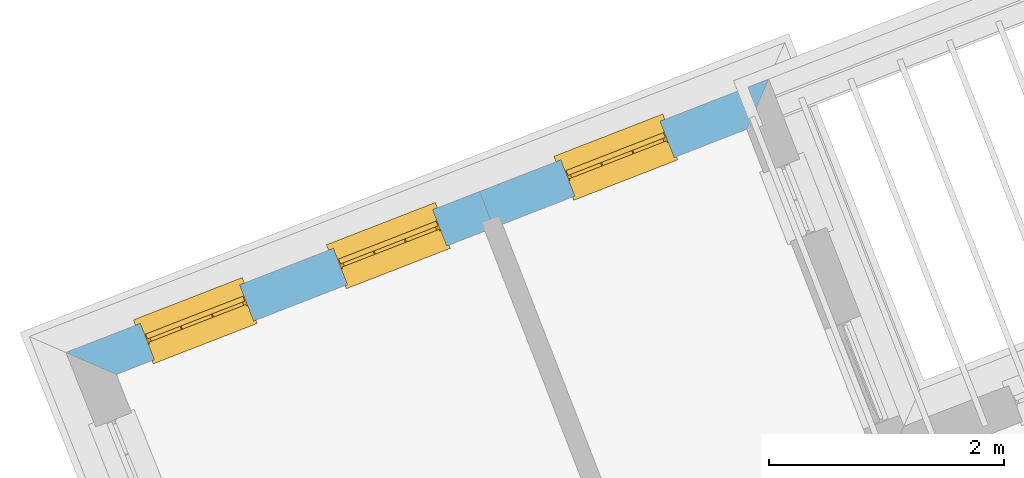
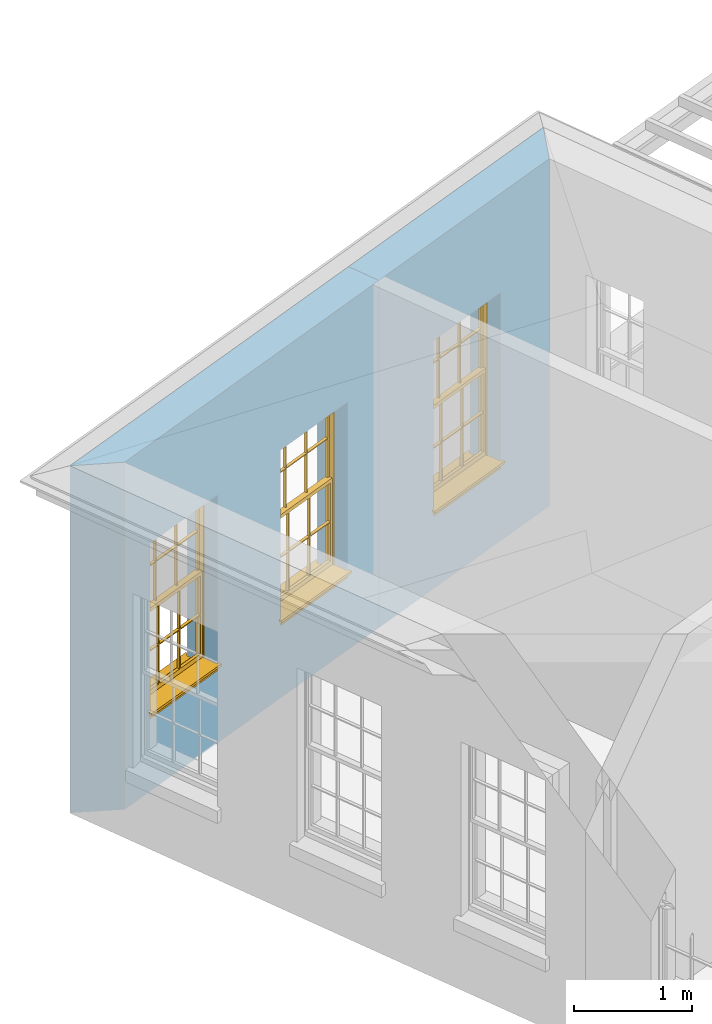
# One storey, part 8 of 11: 3 windows, 3 openings, plus 2 elements that do not belong to this part.
"""IFC2X3 building model written with IfcOpenShell, lengths in metres."""

from ifc_helpers import new_model, si_unit, frame, origin, place, context, subcontext, project, spatial, polyline, outline, extrude, faceted_brep, material, layer, layer_set, layer_usage, element, fill, save


model = new_model("IFC2X3")

# Units and contexts
model_context = context("Model", 3, world=origin())
body_context = subcontext(model_context, "Body", "Model", "MODEL_VIEW")
ifc_project = project(units=[si_unit("PLANEANGLEUNIT", "RADIAN"), si_unit("MASSUNIT", "GRAM", prefix="KILO"), si_unit("FORCEUNIT", "NEWTON", prefix="KILO"), si_unit("LENGTHUNIT", "METRE")], contexts=[model_context])

# Site, building, storey
site_placement = place(None, origin())
site = spatial("IfcSite", under=ifc_project, at=site_placement, CompositionType="ELEMENT")
building_placement = place(None, origin())
building = spatial("IfcBuilding", under=site, at=building_placement, Name="Building plot-3", CompositionType="ELEMENT")
storey_placement = place(None, frame((0.0, 0.0, 5.45)))
storey = spatial("IfcBuildingStorey", under=building, at=storey_placement, Name="Floor 1", CompositionType="ELEMENT", Elevation=5.45)

# Wall, opening, window
ifc_material = material(Name="Masonry")
ifc_layer = layer(ifc_material, 0.33, ventilated=False)
ifc_layer_set = layer_set([ifc_layer], Name="My Wall")
ifc_layer_usage = layer_usage(ifc_layer_set, "AXIS2", "NEGATIVE", 0.08)
wall_1_placement = place(storey_placement, origin())
wall_1 = element("IfcWallStandardCase", 1, at=wall_1_placement, inside=storey, material=ifc_layer_usage, Name="exterior", context=body_context, shape_type="SweptSolid", body=[
    extrude(outline(polyline([(39.2838772821507, 53.1735239406359), (39.4717836497234, 53.6007138246754), (37.0084516896559, 52.6424333407914), (37.1280934478893, 52.3348852149854), (39.2838772821507, 53.1735239406359)])), origin(), (0.0, 0.0, 1.0), 3.6),
])
opening_1_placement = place(storey_placement, frame((0.0, 0.0, 0.75)))
opening_1 = element("IfcOpeningElement", 2, at=opening_1_placement, cuts=wall_1, Name="Opening", ObjectType="Opening", context=body_context, shape_type="SweptSolid", body=[
    extrude(outline(polyline([(38.5476657954957, 53.2412153409668), (37.6995785394851, 52.9112941288686), (37.8192202977185, 52.6037460030626), (38.6673075537291, 52.9336672151608), (38.5476657954957, 53.2412153409668)])), origin(), (0.0, 0.0, 1.0), 1.82),
])
window_1_placement = place(storey_placement, frame((38.6383034911271, 53.0082243365683, 0.75), z_axis=(0.0, 0.0, 1.0), x_axis=(-0.848087256010636, -0.329921212098206, 0.0)))
window_1 = element("IfcWindow", 3, at=window_1_placement, inside=storey, Name="circulation outside window", OverallHeight=1.82, OverallWidth=0.91, context=body_context, shape_type="Brep", held_by="IfcProductRepresentation", body=[
    faceted_brep([(0.033125, -0.105, 0.975209), (0.01, -0.105, 0.975209), (0.033125, -0.105, 1.376042), (0.876875, -0.105, 0.975209), (0.876875, -0.105, 1.376042), (0.9, -0.105, 0.975209), (0.876875, -0.105, 1.386042), (0.876875, -0.105, 1.786875), (0.9, -0.105, 1.81), (0.033125, -0.105, 1.786875), (0.033125, -0.105, 1.386042), (0.01, -0.105, 1.81), (0.876875, -0.135, 1.376042), (0.876875, -0.135, 0.975209), (0.9, -0.135, 0.937083), (0.033125, -0.135, 1.786875), (0.01, -0.135, 1.81), (0.033125, -0.135, 1.386042), (0.01, -0.135, 0.937083), (0.033125, -0.135, 0.975209), (0.033125, -0.135, 1.376042), (0.876875, -0.135, 1.786875), (0.876875, -0.135, 1.386042), (0.9, -0.135, 1.81), (0.033125, -0.105, 0.937083), (0.01, -0.105, 0.937083), (0.033125, -0.105, 0.53625), (0.876875, -0.105, 0.937083), (0.876875, -0.105, 0.53625), (0.9, -0.105, 0.937083), (0.876875, -0.105, 0.52625), (0.876875, -0.105, 0.125417), (0.9, -0.105, 0.077167), (0.033125, -0.105, 0.125417), (0.033125, -0.105, 0.52625), (0.01, -0.105, 0.077167), (-0.0425, -0.25, 0.01), (-0.0425, -0.3, 0.001667), (0.0, -0.25, 0.01), (0.9525, -0.25, 0.01), (0.91, -0.25, 0.01), (0.9525, -0.3, 0.001667), (-0.02, 0.08, 0.077167), (0.0, 0.08, 0.077167), (-0.02, 0.11, 0.077167), (0.0, -0.06, 0.077167), (0.01, -0.06, 0.077167), (0.91, -0.06, 0.077167), (0.91, 0.08, 0.077167), (0.9, -0.06, 0.077167), (0.93, 0.08, 0.077167), (0.93, 0.11, 0.077167), (0.01, -0.075, 0.975209), (0.9, -0.075, 0.975209), (0.876875, -0.075, 0.125417), (0.876875, -0.075, 0.52625), (0.9, -0.075, 0.077167), (0.876875, -0.075, 0.53625), (0.876875, -0.075, 0.937083), (0.033125, -0.075, 0.125417), (0.01, -0.075, 0.077167), (0.033125, -0.075, 0.52625), (0.033125, -0.075, 0.937083), (0.033125, -0.075, 0.53625), (-0.02, 0.08, 0.052167), (-0.02, 0.11, 0.052167), (0.93, 0.11, 0.052167), (0.93, 0.08, 0.052167), (0.91, 0.08, 0.052167), (0.0, 0.08, 0.052167), (0.91, -0.15, 0.026667), (0.0, -0.15, 0.026667), (-0.0425, -0.3, -0.123333), (0.9525, -0.3, -0.123333), (-0.0425, -0.25, -0.123333), (0.9525, -0.25, -0.123333), (0.01, -0.06, 1.81), (0.9, -0.06, 1.81), (0.0, -0.06, 1.82), (0.91, -0.06, 1.82), (0.01, -0.15, 0.077167), (0.9, -0.15, 0.077167), (0.592292, -0.105, 0.125417), (0.592292, -0.075, 0.125417), (0.317708, -0.075, 0.125417), (0.317708, -0.105, 0.125417), (0.592292, -0.105, 0.53625), (0.317708, -0.105, 0.53625), (0.317708, -0.105, 0.52625), (0.592292, -0.105, 0.52625), (0.592292, -0.075, 0.53625), (0.317708, -0.075, 0.53625), (0.592292, -0.135, 1.386042), (0.592292, -0.105, 1.386042), (0.317708, -0.105, 1.386042), (0.317708, -0.135, 1.386042), (0.317708, -0.135, 1.376042), (0.592292, -0.135, 1.376042), (0.317708, -0.105, 1.376042), (0.592292, -0.105, 1.376042), (0.602292, -0.135, 1.376042), (0.592292, -0.135, 0.975209), (0.602292, -0.135, 0.975209), (0.602292, -0.105, 0.975209), (0.592292, -0.105, 0.975209), (0.602292, -0.105, 1.376042), (0.602292, -0.075, 0.53625), (0.602292, -0.105, 0.53625), (0.317708, -0.075, 0.52625), (0.307708, -0.075, 0.125417), (0.307708, -0.075, 0.52625), (0.602292, -0.075, 0.52625), (0.602292, -0.075, 0.125417), (0.592292, -0.075, 0.52625), (0.307708, -0.075, 0.53625), (0.317708, -0.075, 0.937083), (0.307708, -0.075, 0.937083), (0.602292, -0.075, 0.937083), (0.592292, -0.075, 0.937083), (0.307708, -0.105, 0.52625), (0.307708, -0.105, 0.125417), (0.307708, -0.105, 0.53625), (0.307708, -0.105, 0.937083), (0.592292, -0.105, 0.937083), (0.317708, -0.105, 0.937083), (0.602292, -0.105, 0.937083), (0.602292, -0.105, 0.52625), (0.602292, -0.105, 0.125417), (0.307708, -0.135, 1.386042), (0.307708, -0.135, 1.376042), (0.307708, -0.135, 0.975209), (0.317708, -0.135, 0.975209), (0.317708, -0.135, 1.786875), (0.307708, -0.135, 1.786875), (0.602292, -0.135, 1.786875), (0.592292, -0.135, 1.786875), (0.602292, -0.135, 1.386042), (0.602292, -0.105, 1.386042), (0.307708, -0.105, 1.386042), (0.307708, -0.105, 1.786875), (0.317708, -0.105, 1.786875), (0.592292, -0.105, 1.786875), (0.602292, -0.105, 1.786875), (0.307708, -0.105, 1.376042), (0.317708, -0.105, 0.975209), (0.307708, -0.105, 0.975209), (0.91, -0.15, 1.82), (0.9, -0.15, 1.81), (0.01, -0.15, 1.81), (0.0, -0.15, 1.82), (0.91, -0.25, 0.0), (0.0, -0.25, 0.0), (0.91, 0.08, 0.0), (0.0, 0.08, 0.0)], [[[0, 1, 2]], [[3, 4, 5]], [[6, 7, 8]], [[9, 10, 11]], [[12, 13, 14]], [[15, 16, 17]], [[18, 19, 20]], [[21, 22, 23]], [[24, 25, 26]], [[27, 28, 29]], [[30, 31, 32]], [[33, 34, 35]], [[14, 27, 29]], [[25, 24, 18]], [[36, 37, 38]], [[39, 40, 41]], [[42, 43, 44]], [[45, 46, 43]], [[47, 48, 49]], [[50, 51, 48]], [[1, 0, 52]], [[5, 53, 3]], [[54, 55, 56]], [[57, 58, 53]], [[59, 60, 61]], [[62, 63, 52]], [[48, 43, 46, 49]], [[51, 44, 43, 48]], [[64, 42, 44, 65]], [[65, 44, 51, 66]], [[66, 51, 50, 67]], [[65, 66, 68, 69]], [[60, 56, 49, 46]], [[70, 71, 38, 40]], [[37, 41, 40, 38]], [[37, 72, 73, 41]], [[74, 75, 73, 72]], [[8, 11, 76, 77]], [[76, 78, 79, 77]], [[32, 35, 80, 81]], [[81, 80, 71, 70]], [[82, 83, 84, 85]], [[86, 87, 88, 89]], [[86, 90, 91, 87]], [[92, 93, 94, 95]], [[92, 95, 96, 97]], [[96, 98, 99, 97]], [[100, 97, 101, 102]], [[103, 104, 99, 105]], [[97, 99, 104, 101]], [[102, 103, 105, 100]], [[28, 57, 106, 107]], [[108, 84, 109, 110]], [[111, 112, 83, 113]], [[114, 110, 61, 63]], [[90, 113, 108, 91]], [[115, 91, 114, 116]], [[117, 106, 90, 118]], [[111, 106, 57, 55]], [[119, 110, 109, 120]], [[34, 61, 110, 119]], [[89, 113, 83, 82]], [[88, 108, 113, 89]], [[85, 84, 108, 88]], [[121, 114, 63, 26]], [[122, 116, 114, 121]], [[123, 118, 90, 86]], [[87, 91, 115, 124]], [[107, 106, 117, 125]], [[126, 111, 55, 30]], [[127, 112, 111, 126]], [[126, 30, 28, 107]], [[88, 119, 120, 85]], [[126, 89, 82, 127]], [[125, 123, 86, 107]], [[121, 26, 34, 119]], [[124, 122, 121, 87]], [[128, 17, 20, 129]], [[96, 129, 130, 131]], [[132, 133, 128, 95]], [[134, 135, 92, 136]], [[100, 12, 22, 136]], [[137, 6, 4, 105]], [[94, 138, 139, 140]], [[137, 93, 141, 142]], [[99, 98, 94, 93]], [[143, 2, 10, 138]], [[144, 145, 143, 98]], [[129, 143, 145, 130]], [[20, 2, 143, 129]], [[131, 144, 98, 96]], [[128, 138, 10, 17]], [[133, 139, 138, 128]], [[135, 141, 93, 92]], [[95, 94, 140, 132]], [[22, 6, 137, 136]], [[136, 137, 142, 134]], [[100, 105, 4, 12]], [[107, 86, 89, 126]], [[106, 111, 113, 90]], [[91, 108, 110, 114]], [[87, 121, 119, 88]], [[97, 100, 136, 92]], [[129, 96, 95, 128]], [[98, 143, 138, 94]], [[105, 99, 93, 137]], [[131, 101, 104, 144]], [[124, 115, 118, 123]], [[132, 140, 141, 135]], [[120, 109, 59, 33]], [[15, 9, 139, 133]], [[134, 142, 7, 21]], [[31, 54, 112, 127]], [[36, 74, 72, 37]], [[39, 41, 73, 75]], [[18, 14, 101, 131]], [[23, 16, 132, 135]], [[83, 56, 60, 84]], [[52, 53, 118, 115]], [[53, 52, 144, 104]], [[11, 8, 141, 140]], [[14, 18, 124, 123]], [[2, 1, 11, 10]], [[8, 5, 4, 6]], [[57, 53, 56, 55]], [[60, 52, 63, 61]], [[26, 25, 35, 34]], [[32, 29, 28, 30]], [[14, 23, 22, 12]], [[18, 20, 17, 16]], [[19, 0, 2, 20]], [[17, 10, 9, 15]], [[12, 4, 3, 13]], [[21, 7, 6, 22]], [[27, 58, 57, 28]], [[30, 55, 54, 31]], [[33, 59, 61, 34]], [[26, 63, 62, 24]], [[5, 8, 77, 53]], [[76, 11, 1, 52]], [[46, 45, 78, 76]], [[49, 77, 79, 47]], [[70, 146, 147, 81]], [[71, 80, 148, 149]], [[19, 130, 145, 0]], [[102, 13, 3, 103]], [[116, 122, 24, 62]], [[29, 32, 81, 14]], [[80, 35, 25, 18]], [[60, 46, 76, 52]], [[77, 49, 56, 53]], [[23, 14, 81, 147]], [[16, 148, 80, 18]], [[35, 85, 120]], [[120, 33, 35]], [[127, 82, 32]], [[32, 31, 127]], [[32, 82, 85, 35]], [[102, 101, 14]], [[14, 13, 102]], [[18, 131, 130]], [[130, 19, 18]], [[134, 21, 23]], [[23, 135, 134]], [[16, 15, 133]], [[133, 132, 16]], [[11, 140, 139]], [[139, 9, 11]], [[142, 141, 8]], [[8, 7, 142]], [[23, 147, 148, 16]], [[146, 149, 148, 147]], [[52, 115, 116]], [[116, 62, 52]], [[118, 53, 117]], [[58, 117, 53]], [[27, 125, 117, 58]], [[56, 83, 112]], [[112, 54, 56]], [[109, 84, 60]], [[60, 59, 109]], [[125, 27, 14]], [[14, 123, 125]], [[122, 124, 18]], [[18, 24, 122]], [[145, 144, 52]], [[52, 0, 145]], [[103, 3, 53]], [[53, 104, 103]], [[79, 78, 149, 146]], [[78, 45, 71, 149]], [[146, 70, 47, 79]], [[150, 75, 74, 151]], [[68, 66, 67]], [[48, 68, 67, 50]], [[69, 64, 65]], [[42, 64, 69, 43]], [[69, 68, 152, 153]], [[70, 68, 48, 47]], [[150, 152, 68, 70]], [[43, 69, 71, 45]], [[69, 153, 151, 71]], [[152, 150, 151, 153]], [[38, 151, 74, 36]], [[71, 151, 38]], [[39, 75, 150, 40]], [[40, 150, 70]]]),
])
fill(opening_1, window_1)

# Wall, openings, windows
wall_2_placement = place(storey_placement, origin())
wall_2 = element("IfcWallStandardCase", 4, at=wall_2_placement, inside=storey, material=ifc_layer_usage, Name="exterior", context=body_context, shape_type="SweptSolid", body=[
    extrude(outline(polyline([(37.1280934478893, 52.3348852149854), (37.0084516896559, 52.6424333407914), (33.4843052211603, 51.2714769135402), (33.9141530388544, 51.0846045300143), (37.1280934478893, 52.3348852149854)])), origin(), (0.0, 0.0, 1.0), 3.6),
])
opening_2_placement = place(storey_placement, frame((0.0, 0.0, 0.75)))
opening_2 = element("IfcOpeningElement", 5, at=opening_2_placement, cuts=wall_2, Name="Opening", ObjectType="Opening", context=body_context, shape_type="SweptSolid", body=[
    extrude(outline(polyline([(36.6102098481625, 52.4875100942475), (35.7621225921518, 52.1575888821493), (35.8817643503852, 51.8500407563432), (36.7298516063959, 52.1799619684414), (36.6102098481625, 52.4875100942475)])), origin(), (0.0, 0.0, 1.0), 1.82),
])
opening_3_placement = place(storey_placement, frame((0.0, 0.0, 0.75)))
opening_3 = element("IfcOpeningElement", 6, at=opening_3_placement, cuts=wall_2, Name="Opening", ObjectType="Opening", context=body_context, shape_type="SweptSolid", body=[
    extrude(outline(polyline([(34.9656389091649, 51.8477423890613), (34.1175516531543, 51.5178211769631), (34.2371934113877, 51.210273051157), (35.0852806673983, 51.5401942632552), (34.9656389091649, 51.8477423890613)])), origin(), (0.0, 0.0, 1.0), 1.82),
])
window_2_placement = place(storey_placement, frame((36.7008475437938, 52.2545190898489, 0.75), z_axis=(0.0, 0.0, 1.0), x_axis=(-0.848087256010636, -0.329921212098199, 0.0)))
window_2 = element("IfcWindow", 7, at=window_2_placement, inside=storey, Name="bedroom outside window", OverallHeight=1.82, OverallWidth=0.91, context=body_context, shape_type="Brep", held_by="IfcProductRepresentation", body=[
    faceted_brep([(0.033125, -0.105, 0.975209), (0.01, -0.105, 0.975209), (0.033125, -0.105, 1.376042), (0.876875, -0.105, 0.975209), (0.876875, -0.105, 1.376042), (0.9, -0.105, 0.975209), (0.876875, -0.105, 1.386042), (0.876875, -0.105, 1.786875), (0.9, -0.105, 1.81), (0.033125, -0.105, 1.786875), (0.033125, -0.105, 1.386042), (0.01, -0.105, 1.81), (0.876875, -0.135, 1.376042), (0.876875, -0.135, 0.975209), (0.9, -0.135, 0.937083), (0.033125, -0.135, 1.786875), (0.01, -0.135, 1.81), (0.033125, -0.135, 1.386042), (0.01, -0.135, 0.937083), (0.033125, -0.135, 0.975209), (0.033125, -0.135, 1.376042), (0.876875, -0.135, 1.786875), (0.876875, -0.135, 1.386042), (0.9, -0.135, 1.81), (0.033125, -0.105, 0.937083), (0.01, -0.105, 0.937083), (0.033125, -0.105, 0.53625), (0.876875, -0.105, 0.937083), (0.876875, -0.105, 0.53625), (0.9, -0.105, 0.937083), (0.876875, -0.105, 0.52625), (0.876875, -0.105, 0.125417), (0.9, -0.105, 0.077167), (0.033125, -0.105, 0.125417), (0.033125, -0.105, 0.52625), (0.01, -0.105, 0.077167), (-0.0425, -0.25, 0.01), (-0.0425, -0.3, 0.001667), (0.0, -0.25, 0.01), (0.9525, -0.25, 0.01), (0.91, -0.25, 0.01), (0.9525, -0.3, 0.001667), (-0.02, 0.08, 0.077167), (0.0, 0.08, 0.077167), (-0.02, 0.11, 0.077167), (0.0, -0.06, 0.077167), (0.01, -0.06, 0.077167), (0.91, -0.06, 0.077167), (0.91, 0.08, 0.077167), (0.9, -0.06, 0.077167), (0.93, 0.08, 0.077167), (0.93, 0.11, 0.077167), (0.01, -0.075, 0.975209), (0.9, -0.075, 0.975209), (0.876875, -0.075, 0.125417), (0.876875, -0.075, 0.52625), (0.9, -0.075, 0.077167), (0.876875, -0.075, 0.53625), (0.876875, -0.075, 0.937083), (0.033125, -0.075, 0.125417), (0.01, -0.075, 0.077167), (0.033125, -0.075, 0.52625), (0.033125, -0.075, 0.937083), (0.033125, -0.075, 0.53625), (-0.02, 0.08, 0.052167), (-0.02, 0.11, 0.052167), (0.93, 0.11, 0.052167), (0.93, 0.08, 0.052167), (0.91, 0.08, 0.052167), (0.0, 0.08, 0.052167), (0.91, -0.15, 0.026667), (0.0, -0.15, 0.026667), (-0.0425, -0.3, -0.123333), (0.9525, -0.3, -0.123333), (-0.0425, -0.25, -0.123333), (0.9525, -0.25, -0.123333), (0.01, -0.06, 1.81), (0.9, -0.06, 1.81), (0.0, -0.06, 1.82), (0.91, -0.06, 1.82), (0.01, -0.15, 0.077167), (0.9, -0.15, 0.077167), (0.592292, -0.105, 0.125417), (0.592292, -0.075, 0.125417), (0.317708, -0.075, 0.125417), (0.317708, -0.105, 0.125417), (0.592292, -0.105, 0.53625), (0.317708, -0.105, 0.53625), (0.317708, -0.105, 0.52625), (0.592292, -0.105, 0.52625), (0.592292, -0.075, 0.53625), (0.317708, -0.075, 0.53625), (0.592292, -0.135, 1.386042), (0.592292, -0.105, 1.386042), (0.317708, -0.105, 1.386042), (0.317708, -0.135, 1.386042), (0.317708, -0.135, 1.376042), (0.592292, -0.135, 1.376042), (0.317708, -0.105, 1.376042), (0.592292, -0.105, 1.376042), (0.602292, -0.135, 1.376042), (0.592292, -0.135, 0.975209), (0.602292, -0.135, 0.975209), (0.602292, -0.105, 0.975209), (0.592292, -0.105, 0.975209), (0.602292, -0.105, 1.376042), (0.602292, -0.075, 0.53625), (0.602292, -0.105, 0.53625), (0.317708, -0.075, 0.52625), (0.307708, -0.075, 0.125417), (0.307708, -0.075, 0.52625), (0.602292, -0.075, 0.52625), (0.602292, -0.075, 0.125417), (0.592292, -0.075, 0.52625), (0.307708, -0.075, 0.53625), (0.317708, -0.075, 0.937083), (0.307708, -0.075, 0.937083), (0.602292, -0.075, 0.937083), (0.592292, -0.075, 0.937083), (0.307708, -0.105, 0.52625), (0.307708, -0.105, 0.125417), (0.307708, -0.105, 0.53625), (0.307708, -0.105, 0.937083), (0.592292, -0.105, 0.937083), (0.317708, -0.105, 0.937083), (0.602292, -0.105, 0.937083), (0.602292, -0.105, 0.52625), (0.602292, -0.105, 0.125417), (0.307708, -0.135, 1.386042), (0.307708, -0.135, 1.376042), (0.307708, -0.135, 0.975209), (0.317708, -0.135, 0.975209), (0.317708, -0.135, 1.786875), (0.307708, -0.135, 1.786875), (0.602292, -0.135, 1.786875), (0.592292, -0.135, 1.786875), (0.602292, -0.135, 1.386042), (0.602292, -0.105, 1.386042), (0.307708, -0.105, 1.386042), (0.307708, -0.105, 1.786875), (0.317708, -0.105, 1.786875), (0.592292, -0.105, 1.786875), (0.602292, -0.105, 1.786875), (0.307708, -0.105, 1.376042), (0.317708, -0.105, 0.975209), (0.307708, -0.105, 0.975209), (0.91, -0.15, 1.82), (0.9, -0.15, 1.81), (0.01, -0.15, 1.81), (0.0, -0.15, 1.82), (0.91, -0.25, 0.0), (0.0, -0.25, 0.0), (0.91, 0.08, 0.0), (0.0, 0.08, 0.0)], [[[0, 1, 2]], [[3, 4, 5]], [[6, 7, 8]], [[9, 10, 11]], [[12, 13, 14]], [[15, 16, 17]], [[18, 19, 20]], [[21, 22, 23]], [[24, 25, 26]], [[27, 28, 29]], [[30, 31, 32]], [[33, 34, 35]], [[14, 27, 29]], [[25, 24, 18]], [[36, 37, 38]], [[39, 40, 41]], [[42, 43, 44]], [[45, 46, 43]], [[47, 48, 49]], [[50, 51, 48]], [[1, 0, 52]], [[5, 53, 3]], [[54, 55, 56]], [[57, 58, 53]], [[59, 60, 61]], [[62, 63, 52]], [[48, 43, 46, 49]], [[51, 44, 43, 48]], [[64, 42, 44, 65]], [[65, 44, 51, 66]], [[66, 51, 50, 67]], [[65, 66, 68, 69]], [[60, 56, 49, 46]], [[70, 71, 38, 40]], [[37, 41, 40, 38]], [[37, 72, 73, 41]], [[74, 75, 73, 72]], [[8, 11, 76, 77]], [[76, 78, 79, 77]], [[32, 35, 80, 81]], [[81, 80, 71, 70]], [[82, 83, 84, 85]], [[86, 87, 88, 89]], [[86, 90, 91, 87]], [[92, 93, 94, 95]], [[92, 95, 96, 97]], [[96, 98, 99, 97]], [[100, 97, 101, 102]], [[103, 104, 99, 105]], [[97, 99, 104, 101]], [[102, 103, 105, 100]], [[28, 57, 106, 107]], [[108, 84, 109, 110]], [[111, 112, 83, 113]], [[114, 110, 61, 63]], [[90, 113, 108, 91]], [[115, 91, 114, 116]], [[117, 106, 90, 118]], [[111, 106, 57, 55]], [[119, 110, 109, 120]], [[34, 61, 110, 119]], [[89, 113, 83, 82]], [[88, 108, 113, 89]], [[85, 84, 108, 88]], [[121, 114, 63, 26]], [[122, 116, 114, 121]], [[123, 118, 90, 86]], [[87, 91, 115, 124]], [[107, 106, 117, 125]], [[126, 111, 55, 30]], [[127, 112, 111, 126]], [[126, 30, 28, 107]], [[88, 119, 120, 85]], [[126, 89, 82, 127]], [[125, 123, 86, 107]], [[121, 26, 34, 119]], [[124, 122, 121, 87]], [[128, 17, 20, 129]], [[96, 129, 130, 131]], [[132, 133, 128, 95]], [[134, 135, 92, 136]], [[100, 12, 22, 136]], [[137, 6, 4, 105]], [[94, 138, 139, 140]], [[137, 93, 141, 142]], [[99, 98, 94, 93]], [[143, 2, 10, 138]], [[144, 145, 143, 98]], [[129, 143, 145, 130]], [[20, 2, 143, 129]], [[131, 144, 98, 96]], [[128, 138, 10, 17]], [[133, 139, 138, 128]], [[135, 141, 93, 92]], [[95, 94, 140, 132]], [[22, 6, 137, 136]], [[136, 137, 142, 134]], [[100, 105, 4, 12]], [[107, 86, 89, 126]], [[106, 111, 113, 90]], [[91, 108, 110, 114]], [[87, 121, 119, 88]], [[97, 100, 136, 92]], [[129, 96, 95, 128]], [[98, 143, 138, 94]], [[105, 99, 93, 137]], [[131, 101, 104, 144]], [[124, 115, 118, 123]], [[132, 140, 141, 135]], [[120, 109, 59, 33]], [[15, 9, 139, 133]], [[134, 142, 7, 21]], [[31, 54, 112, 127]], [[36, 74, 72, 37]], [[39, 41, 73, 75]], [[18, 14, 101, 131]], [[23, 16, 132, 135]], [[83, 56, 60, 84]], [[52, 53, 118, 115]], [[53, 52, 144, 104]], [[11, 8, 141, 140]], [[14, 18, 124, 123]], [[2, 1, 11, 10]], [[8, 5, 4, 6]], [[57, 53, 56, 55]], [[60, 52, 63, 61]], [[26, 25, 35, 34]], [[32, 29, 28, 30]], [[14, 23, 22, 12]], [[18, 20, 17, 16]], [[19, 0, 2, 20]], [[17, 10, 9, 15]], [[12, 4, 3, 13]], [[21, 7, 6, 22]], [[27, 58, 57, 28]], [[30, 55, 54, 31]], [[33, 59, 61, 34]], [[26, 63, 62, 24]], [[5, 8, 77, 53]], [[76, 11, 1, 52]], [[46, 45, 78, 76]], [[49, 77, 79, 47]], [[70, 146, 147, 81]], [[71, 80, 148, 149]], [[19, 130, 145, 0]], [[102, 13, 3, 103]], [[116, 122, 24, 62]], [[29, 32, 81, 14]], [[80, 35, 25, 18]], [[60, 46, 76, 52]], [[77, 49, 56, 53]], [[23, 14, 81, 147]], [[16, 148, 80, 18]], [[35, 85, 120]], [[120, 33, 35]], [[127, 82, 32]], [[32, 31, 127]], [[32, 82, 85, 35]], [[102, 101, 14]], [[14, 13, 102]], [[18, 131, 130]], [[130, 19, 18]], [[134, 21, 23]], [[23, 135, 134]], [[16, 15, 133]], [[133, 132, 16]], [[11, 140, 139]], [[139, 9, 11]], [[142, 141, 8]], [[8, 7, 142]], [[23, 147, 148, 16]], [[146, 149, 148, 147]], [[52, 115, 116]], [[116, 62, 52]], [[118, 53, 117]], [[58, 117, 53]], [[27, 125, 117, 58]], [[56, 83, 112]], [[112, 54, 56]], [[109, 84, 60]], [[60, 59, 109]], [[125, 27, 14]], [[14, 123, 125]], [[122, 124, 18]], [[18, 24, 122]], [[145, 144, 52]], [[52, 0, 145]], [[103, 3, 53]], [[53, 104, 103]], [[79, 78, 149, 146]], [[78, 45, 71, 149]], [[146, 70, 47, 79]], [[150, 75, 74, 151]], [[68, 66, 67]], [[48, 68, 67, 50]], [[69, 64, 65]], [[42, 64, 69, 43]], [[69, 68, 152, 153]], [[70, 68, 48, 47]], [[150, 152, 68, 70]], [[43, 69, 71, 45]], [[69, 153, 151, 71]], [[152, 150, 151, 153]], [[38, 151, 74, 36]], [[71, 151, 38]], [[39, 75, 150, 40]], [[40, 150, 70]]]),
])
fill(opening_2, window_2)
window_3_placement = place(storey_placement, frame((35.0562766047963, 51.6147513846628, 0.75), z_axis=(0.0, 0.0, 1.0), x_axis=(-0.848087256010636, -0.329921212098199, 0.0)))
window_3 = element("IfcWindow", 8, at=window_3_placement, inside=storey, Name="bedroom outside window", OverallHeight=1.82, OverallWidth=0.91, context=body_context, shape_type="Brep", held_by="IfcProductRepresentation", body=[
    faceted_brep([(0.033125, -0.105, 0.975209), (0.01, -0.105, 0.975209), (0.033125, -0.105, 1.376042), (0.876875, -0.105, 0.975209), (0.876875, -0.105, 1.376042), (0.9, -0.105, 0.975209), (0.876875, -0.105, 1.386042), (0.876875, -0.105, 1.786875), (0.9, -0.105, 1.81), (0.033125, -0.105, 1.786875), (0.033125, -0.105, 1.386042), (0.01, -0.105, 1.81), (0.876875, -0.135, 1.376042), (0.876875, -0.135, 0.975209), (0.9, -0.135, 0.937083), (0.033125, -0.135, 1.786875), (0.01, -0.135, 1.81), (0.033125, -0.135, 1.386042), (0.01, -0.135, 0.937083), (0.033125, -0.135, 0.975209), (0.033125, -0.135, 1.376042), (0.876875, -0.135, 1.786875), (0.876875, -0.135, 1.386042), (0.9, -0.135, 1.81), (0.033125, -0.105, 0.937083), (0.01, -0.105, 0.937083), (0.033125, -0.105, 0.53625), (0.876875, -0.105, 0.937083), (0.876875, -0.105, 0.53625), (0.9, -0.105, 0.937083), (0.876875, -0.105, 0.52625), (0.876875, -0.105, 0.125417), (0.9, -0.105, 0.077167), (0.033125, -0.105, 0.125417), (0.033125, -0.105, 0.52625), (0.01, -0.105, 0.077167), (-0.0425, -0.25, 0.01), (-0.0425, -0.3, 0.001667), (0.0, -0.25, 0.01), (0.9525, -0.25, 0.01), (0.91, -0.25, 0.01), (0.9525, -0.3, 0.001667), (-0.02, 0.08, 0.077167), (0.0, 0.08, 0.077167), (-0.02, 0.11, 0.077167), (0.0, -0.06, 0.077167), (0.01, -0.06, 0.077167), (0.91, -0.06, 0.077167), (0.91, 0.08, 0.077167), (0.9, -0.06, 0.077167), (0.93, 0.08, 0.077167), (0.93, 0.11, 0.077167), (0.01, -0.075, 0.975209), (0.9, -0.075, 0.975209), (0.876875, -0.075, 0.125417), (0.876875, -0.075, 0.52625), (0.9, -0.075, 0.077167), (0.876875, -0.075, 0.53625), (0.876875, -0.075, 0.937083), (0.033125, -0.075, 0.125417), (0.01, -0.075, 0.077167), (0.033125, -0.075, 0.52625), (0.033125, -0.075, 0.937083), (0.033125, -0.075, 0.53625), (-0.02, 0.08, 0.052167), (-0.02, 0.11, 0.052167), (0.93, 0.11, 0.052167), (0.93, 0.08, 0.052167), (0.91, 0.08, 0.052167), (0.0, 0.08, 0.052167), (0.91, -0.15, 0.026667), (0.0, -0.15, 0.026667), (-0.0425, -0.3, -0.123333), (0.9525, -0.3, -0.123333), (-0.0425, -0.25, -0.123333), (0.9525, -0.25, -0.123333), (0.01, -0.06, 1.81), (0.9, -0.06, 1.81), (0.0, -0.06, 1.82), (0.91, -0.06, 1.82), (0.01, -0.15, 0.077167), (0.9, -0.15, 0.077167), (0.592292, -0.105, 0.125417), (0.592292, -0.075, 0.125417), (0.317708, -0.075, 0.125417), (0.317708, -0.105, 0.125417), (0.592292, -0.105, 0.53625), (0.317708, -0.105, 0.53625), (0.317708, -0.105, 0.52625), (0.592292, -0.105, 0.52625), (0.592292, -0.075, 0.53625), (0.317708, -0.075, 0.53625), (0.592292, -0.135, 1.386042), (0.592292, -0.105, 1.386042), (0.317708, -0.105, 1.386042), (0.317708, -0.135, 1.386042), (0.317708, -0.135, 1.376042), (0.592292, -0.135, 1.376042), (0.317708, -0.105, 1.376042), (0.592292, -0.105, 1.376042), (0.602292, -0.135, 1.376042), (0.592292, -0.135, 0.975209), (0.602292, -0.135, 0.975209), (0.602292, -0.105, 0.975209), (0.592292, -0.105, 0.975209), (0.602292, -0.105, 1.376042), (0.602292, -0.075, 0.53625), (0.602292, -0.105, 0.53625), (0.317708, -0.075, 0.52625), (0.307708, -0.075, 0.125417), (0.307708, -0.075, 0.52625), (0.602292, -0.075, 0.52625), (0.602292, -0.075, 0.125417), (0.592292, -0.075, 0.52625), (0.307708, -0.075, 0.53625), (0.317708, -0.075, 0.937083), (0.307708, -0.075, 0.937083), (0.602292, -0.075, 0.937083), (0.592292, -0.075, 0.937083), (0.307708, -0.105, 0.52625), (0.307708, -0.105, 0.125417), (0.307708, -0.105, 0.53625), (0.307708, -0.105, 0.937083), (0.592292, -0.105, 0.937083), (0.317708, -0.105, 0.937083), (0.602292, -0.105, 0.937083), (0.602292, -0.105, 0.52625), (0.602292, -0.105, 0.125417), (0.307708, -0.135, 1.386042), (0.307708, -0.135, 1.376042), (0.307708, -0.135, 0.975209), (0.317708, -0.135, 0.975209), (0.317708, -0.135, 1.786875), (0.307708, -0.135, 1.786875), (0.602292, -0.135, 1.786875), (0.592292, -0.135, 1.786875), (0.602292, -0.135, 1.386042), (0.602292, -0.105, 1.386042), (0.307708, -0.105, 1.386042), (0.307708, -0.105, 1.786875), (0.317708, -0.105, 1.786875), (0.592292, -0.105, 1.786875), (0.602292, -0.105, 1.786875), (0.307708, -0.105, 1.376042), (0.317708, -0.105, 0.975209), (0.307708, -0.105, 0.975209), (0.91, -0.15, 1.82), (0.9, -0.15, 1.81), (0.01, -0.15, 1.81), (0.0, -0.15, 1.82), (0.91, -0.25, 0.0), (0.0, -0.25, 0.0), (0.91, 0.08, 0.0), (0.0, 0.08, 0.0)], [[[0, 1, 2]], [[3, 4, 5]], [[6, 7, 8]], [[9, 10, 11]], [[12, 13, 14]], [[15, 16, 17]], [[18, 19, 20]], [[21, 22, 23]], [[24, 25, 26]], [[27, 28, 29]], [[30, 31, 32]], [[33, 34, 35]], [[14, 27, 29]], [[25, 24, 18]], [[36, 37, 38]], [[39, 40, 41]], [[42, 43, 44]], [[45, 46, 43]], [[47, 48, 49]], [[50, 51, 48]], [[1, 0, 52]], [[5, 53, 3]], [[54, 55, 56]], [[57, 58, 53]], [[59, 60, 61]], [[62, 63, 52]], [[48, 43, 46, 49]], [[51, 44, 43, 48]], [[64, 42, 44, 65]], [[65, 44, 51, 66]], [[66, 51, 50, 67]], [[65, 66, 68, 69]], [[60, 56, 49, 46]], [[70, 71, 38, 40]], [[37, 41, 40, 38]], [[37, 72, 73, 41]], [[74, 75, 73, 72]], [[8, 11, 76, 77]], [[76, 78, 79, 77]], [[32, 35, 80, 81]], [[81, 80, 71, 70]], [[82, 83, 84, 85]], [[86, 87, 88, 89]], [[86, 90, 91, 87]], [[92, 93, 94, 95]], [[92, 95, 96, 97]], [[96, 98, 99, 97]], [[100, 97, 101, 102]], [[103, 104, 99, 105]], [[97, 99, 104, 101]], [[102, 103, 105, 100]], [[28, 57, 106, 107]], [[108, 84, 109, 110]], [[111, 112, 83, 113]], [[114, 110, 61, 63]], [[90, 113, 108, 91]], [[115, 91, 114, 116]], [[117, 106, 90, 118]], [[111, 106, 57, 55]], [[119, 110, 109, 120]], [[34, 61, 110, 119]], [[89, 113, 83, 82]], [[88, 108, 113, 89]], [[85, 84, 108, 88]], [[121, 114, 63, 26]], [[122, 116, 114, 121]], [[123, 118, 90, 86]], [[87, 91, 115, 124]], [[107, 106, 117, 125]], [[126, 111, 55, 30]], [[127, 112, 111, 126]], [[126, 30, 28, 107]], [[88, 119, 120, 85]], [[126, 89, 82, 127]], [[125, 123, 86, 107]], [[121, 26, 34, 119]], [[124, 122, 121, 87]], [[128, 17, 20, 129]], [[96, 129, 130, 131]], [[132, 133, 128, 95]], [[134, 135, 92, 136]], [[100, 12, 22, 136]], [[137, 6, 4, 105]], [[94, 138, 139, 140]], [[137, 93, 141, 142]], [[99, 98, 94, 93]], [[143, 2, 10, 138]], [[144, 145, 143, 98]], [[129, 143, 145, 130]], [[20, 2, 143, 129]], [[131, 144, 98, 96]], [[128, 138, 10, 17]], [[133, 139, 138, 128]], [[135, 141, 93, 92]], [[95, 94, 140, 132]], [[22, 6, 137, 136]], [[136, 137, 142, 134]], [[100, 105, 4, 12]], [[107, 86, 89, 126]], [[106, 111, 113, 90]], [[91, 108, 110, 114]], [[87, 121, 119, 88]], [[97, 100, 136, 92]], [[129, 96, 95, 128]], [[98, 143, 138, 94]], [[105, 99, 93, 137]], [[131, 101, 104, 144]], [[124, 115, 118, 123]], [[132, 140, 141, 135]], [[120, 109, 59, 33]], [[15, 9, 139, 133]], [[134, 142, 7, 21]], [[31, 54, 112, 127]], [[36, 74, 72, 37]], [[39, 41, 73, 75]], [[18, 14, 101, 131]], [[23, 16, 132, 135]], [[83, 56, 60, 84]], [[52, 53, 118, 115]], [[53, 52, 144, 104]], [[11, 8, 141, 140]], [[14, 18, 124, 123]], [[2, 1, 11, 10]], [[8, 5, 4, 6]], [[57, 53, 56, 55]], [[60, 52, 63, 61]], [[26, 25, 35, 34]], [[32, 29, 28, 30]], [[14, 23, 22, 12]], [[18, 20, 17, 16]], [[19, 0, 2, 20]], [[17, 10, 9, 15]], [[12, 4, 3, 13]], [[21, 7, 6, 22]], [[27, 58, 57, 28]], [[30, 55, 54, 31]], [[33, 59, 61, 34]], [[26, 63, 62, 24]], [[5, 8, 77, 53]], [[76, 11, 1, 52]], [[46, 45, 78, 76]], [[49, 77, 79, 47]], [[70, 146, 147, 81]], [[71, 80, 148, 149]], [[19, 130, 145, 0]], [[102, 13, 3, 103]], [[116, 122, 24, 62]], [[29, 32, 81, 14]], [[80, 35, 25, 18]], [[60, 46, 76, 52]], [[77, 49, 56, 53]], [[23, 14, 81, 147]], [[16, 148, 80, 18]], [[35, 85, 120]], [[120, 33, 35]], [[127, 82, 32]], [[32, 31, 127]], [[32, 82, 85, 35]], [[102, 101, 14]], [[14, 13, 102]], [[18, 131, 130]], [[130, 19, 18]], [[134, 21, 23]], [[23, 135, 134]], [[16, 15, 133]], [[133, 132, 16]], [[11, 140, 139]], [[139, 9, 11]], [[142, 141, 8]], [[8, 7, 142]], [[23, 147, 148, 16]], [[146, 149, 148, 147]], [[52, 115, 116]], [[116, 62, 52]], [[118, 53, 117]], [[58, 117, 53]], [[27, 125, 117, 58]], [[56, 83, 112]], [[112, 54, 56]], [[109, 84, 60]], [[60, 59, 109]], [[125, 27, 14]], [[14, 123, 125]], [[122, 124, 18]], [[18, 24, 122]], [[145, 144, 52]], [[52, 0, 145]], [[103, 3, 53]], [[53, 104, 103]], [[79, 78, 149, 146]], [[78, 45, 71, 149]], [[146, 70, 47, 79]], [[150, 75, 74, 151]], [[68, 66, 67]], [[48, 68, 67, 50]], [[69, 64, 65]], [[42, 64, 69, 43]], [[69, 68, 152, 153]], [[70, 68, 48, 47]], [[150, 152, 68, 70]], [[43, 69, 71, 45]], [[69, 153, 151, 71]], [[152, 150, 151, 153]], [[38, 151, 74, 36]], [[71, 151, 38]], [[39, 75, 150, 40]], [[40, 150, 70]]]),
])
fill(opening_3, window_3)

save(model, "model.ifc")
